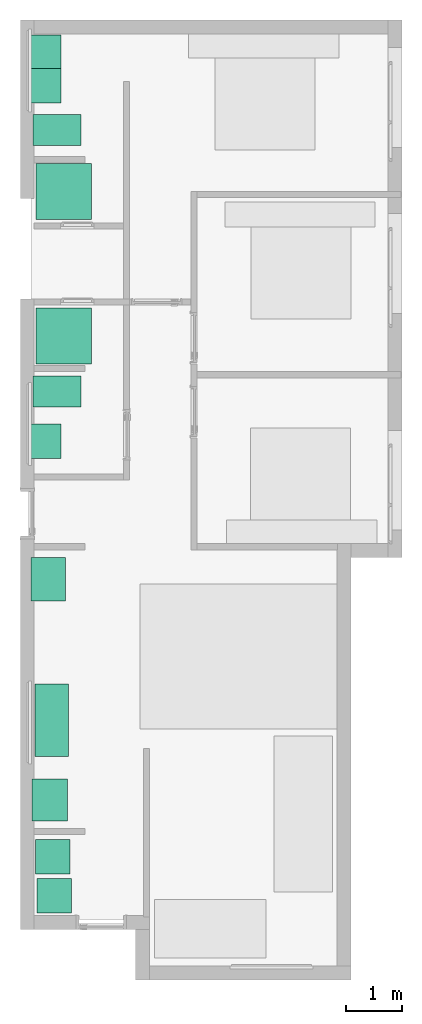
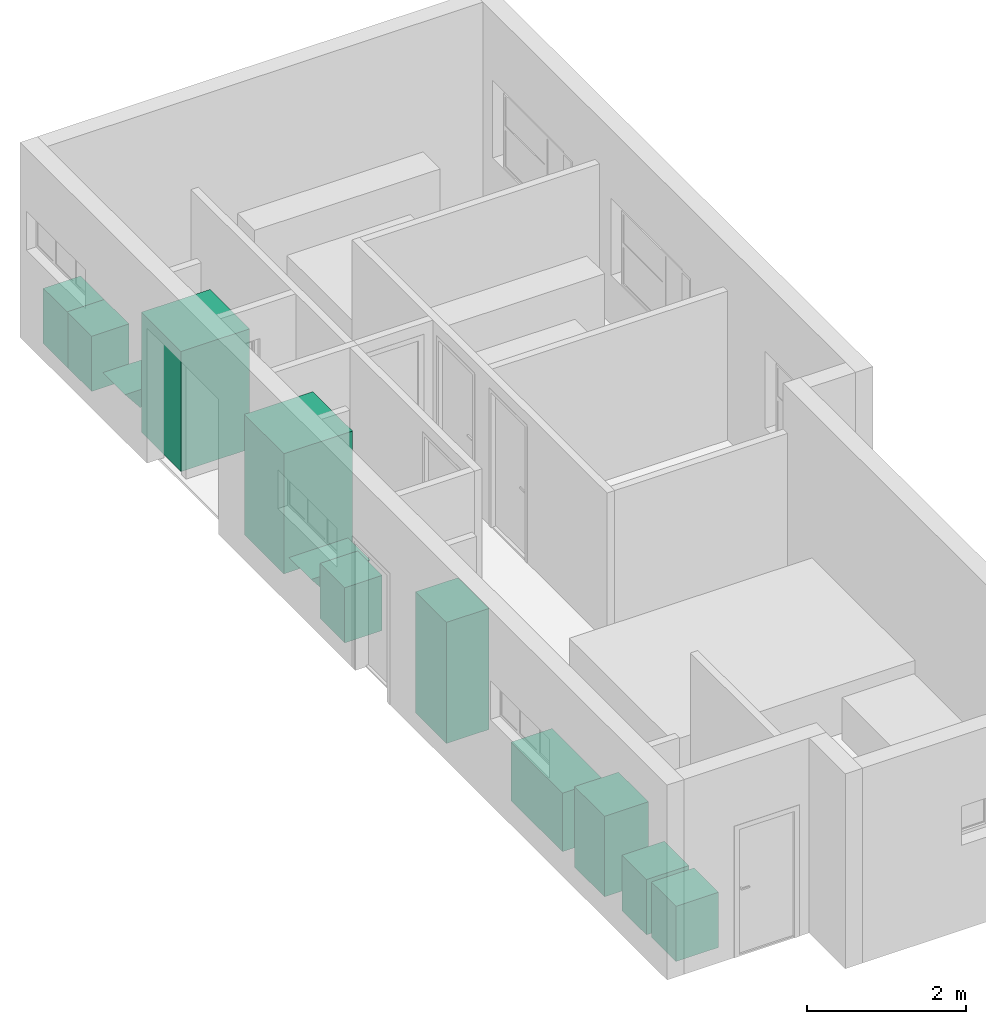
# One storey, part 9 of 10: 8 sanitary terminals, 4 electric appliances.
"""IFC4 building model written with IfcOpenShell, lengths in millimetres."""

from ifc_helpers import new_model, entity, si_unit, converted_unit, frame, origin_with_axes, origin_2d_with_axis, place, context, subcontext, project, spatial, polygons, source, transform, mapped, type_object, type_shapes, element, save


model = new_model("IFC4")

# Units and contexts
model_context = context("Model", 3, precision=1e-05, world=origin_with_axes())
plan_context = context("Plan", 2, precision=1e-05, world=origin_2d_with_axis())
body_context = subcontext(model_context, "Body", "Model", "MODEL_VIEW")
ifc_project = project(units=[si_unit("VOLUMEUNIT", "CUBIC_METRE"), si_unit("LENGTHUNIT", "METRE", prefix="MILLI"), converted_unit("PLANEANGLEUNIT", "degree", entity("IfcReal", 0.0174532925199433), si_unit("PLANEANGLEUNIT", "RADIAN"), dimensions=[0, 0, 0, 0, 0, 0, 0]), si_unit("AREAUNIT", "SQUARE_METRE")], contexts=[model_context, plan_context])

# Site, building, storey
site_placement = place(None, origin_with_axes())
site = spatial("IfcSite", under=ifc_project, at=site_placement)
building_placement = place(site_placement, origin_with_axes())
building = spatial("IfcBuilding", under=site, at=building_placement, Name="Building")
storey_placement = place(building_placement, origin_with_axes())
storey = spatial("IfcBuildingStorey", under=building, at=storey_placement, Name="0-Ground Floor")

# Electric appliances
electric_appliance_type_1 = type_object("IfcElectricApplianceType", Name="13 plate DW", PredefinedType="DISHWASHER")
shared_shape_1 = source(origin_with_axes(), body_context, "Body", "Tessellation", [
    polygons([(-25.4548778533936, -5.45489740371704, 2.98023205687059e-05), (-25.4548778533936, 614.544921875, 2.98023205687059e-05), (-25.4548778533936, -5.45489740371704, 850.0), (-25.4548778533936, 614.544921875, 850.0), (594.545043945312, 614.544921875, 2.98023205687059e-05), (594.545043945312, 614.544921875, 850.0), (594.545043945312, -5.45489740371704, 2.98023205687059e-05), (594.545043945312, -5.45489740371704, 850.0)], [[[2, 4, 6, 5]], [[5, 6, 8, 7]], [[7, 1, 2, 5]], [[3, 8, 6, 4]], [[3, 1, 7, 8]], [[4, 2, 1, 3]]], closed=True),
])
type_shapes(electric_appliance_type_1, [shared_shape_1])
electric_appliance_1_placement = place(storey_placement, frame((1639.33420181274, 2875.96201896667, 0.0), z_axis=(0.0, 0.0, 1.0), x_axis=(1.0, 0.0, 0.0)))
element("IfcElectricAppliance", 1, at=electric_appliance_1_placement, inside=storey, type_object=electric_appliance_type_1, Name="ElectricAppliance", context=body_context, shape_type="MappedRepresentation", body=[
    mapped(shared_shape_1, transform((0.0, 0.0, 0.0), x_axis=(1.0, 0.0, 0.0), y_axis=(0.0, 1.0, 0.0), z_axis=(0.0, 0.0, 1.0), scale=1.0)),
])
electric_appliance_type_2 = type_object("IfcElectricApplianceType", PredefinedType="WASHINGMACHINE")
shared_shape_2 = source(origin_with_axes(), body_context, "Body", "Tessellation", [
    polygons([(1.86264496733202e-05, 0.0, 2.98023205687059e-05), (1.86264496733202e-05, 619.999938964844, 2.98023205687059e-05), (1.86264496733202e-05, 0.0, 850.0), (1.86264496733202e-05, 619.999938964844, 850.0), (619.999938964844, 619.999938964844, 2.98023205687059e-05), (619.999938964844, 619.999938964844, 850.0), (619.999938964844, 0.0, 2.98023205687059e-05), (619.999938964844, 0.0, 850.0)], [[[2, 4, 6, 5]], [[5, 6, 8, 7]], [[7, 1, 2, 5]], [[3, 8, 6, 4]], [[3, 1, 7, 8]], [[4, 2, 1, 3]]], closed=True),
])
type_shapes(electric_appliance_type_2, [shared_shape_2])
electric_appliance_2_placement = place(storey_placement, frame((1643.49460601807, 2175.20189285278, 0.0), z_axis=(0.0, 0.0, 1.0), x_axis=(1.0, 0.0, 0.0)))
element("IfcElectricAppliance", 2, at=electric_appliance_2_placement, inside=storey, type_object=electric_appliance_type_2, Name="ElectricAppliance", context=body_context, shape_type="MappedRepresentation", body=[
    mapped(shared_shape_2, transform((0.0, 0.0, 0.0), x_axis=(1.0, 0.0, 0.0), y_axis=(0.0, 1.0, 0.0), z_axis=(0.0, 0.0, 1.0), scale=1.0)),
])
electric_appliance_type_3 = type_object("IfcElectricApplianceType", PredefinedType="FRIDGE_FREEZER")
shared_shape_3 = source(origin_with_axes(), body_context, "Body", "Tessellation", [
    polygons([(2.98023187497165e-05, 779.999877929688, 2.98023187497165e-05), (619.999877929688, 779.999877929688, 2.98023187497165e-05), (2.98023187497165e-05, 779.999877929688, 1864.99975585938), (619.999877929688, 779.999877929688, 1864.99975585938), (619.999877929688, 2.98023187497165e-05, 2.98023187497165e-05), (619.999877929688, 2.98023187497165e-05, 1864.99975585938), (2.98023187497165e-05, 2.98023187497165e-05, 2.98023187497165e-05), (2.98023187497165e-05, 2.98023187497165e-05, 1864.99975585938)], [[[2, 1, 3]], [[2, 3, 4]], [[6, 5, 2]], [[6, 2, 4]], [[1, 2, 5]], [[1, 5, 7]], [[4, 3, 8]], [[4, 8, 6]], [[5, 6, 8]], [[5, 8, 7]], [[8, 3, 1]], [[8, 1, 7]]], closed=True),
])
type_shapes(electric_appliance_type_3, [shared_shape_3])
electric_appliance_3_placement = place(storey_placement, frame((2153.04899215698, 8553.37905883789, 0.0), z_axis=(0.0, 0.0, 1.0), x_axis=(-0.999999999999989, 1.50995802528085e-07, 0.0)))
element("IfcElectricAppliance", 3, at=electric_appliance_3_placement, inside=storey, type_object=electric_appliance_type_3, Name="ElectricAppliance", context=body_context, shape_type="MappedRepresentation", body=[
    mapped(shared_shape_3, transform((0.0, 0.0, 0.0), x_axis=(1.0, 0.0, 0.0), y_axis=(0.0, 1.0, 0.0), z_axis=(0.0, 0.0, 1.0), scale=1.0)),
])
electric_appliance_type_4 = type_object("IfcElectricApplianceType", PredefinedType="ELECTRICCOOKER")
shared_shape_4 = source(origin_with_axes(), body_context, "Body", "Tessellation", [
    polygons([(-3.21423983573914, 11.3971147537231, 26.0084190368652), (-3.21423983573914, 11.3971147537231, 1266.00842285156), (-3.21423983573914, 651.397094726562, 26.0084190368652), (-3.21423983573914, 651.397094726562, 1266.00842285156), (751.785705566406, 11.3971147537231, 26.0084190368652), (751.785705566406, 11.3971147537231, 1266.00842285156), (751.785705566406, 651.397094726562, 26.0084190368652), (751.785705566406, 651.397094726562, 1266.00842285156)], [[[1, 2, 4, 3]], [[3, 4, 8, 7]], [[7, 8, 6, 5]], [[5, 6, 2, 1]], [[3, 7, 5, 1]], [[8, 4, 2, 6]]], closed=True),
])
type_shapes(electric_appliance_type_4, [shared_shape_4])
electric_appliance_4_placement = place(storey_placement, frame((1543.6372756958, 4577.67343521118, 0.0), z_axis=(0.0, 0.0, 1.0), x_axis=(7.54979012640431e-08, -0.999999999999997, 0.0)))
element("IfcElectricAppliance", 4, at=electric_appliance_4_placement, inside=storey, type_object=electric_appliance_type_4, Name="ElectricAppliance", context=body_context, shape_type="MappedRepresentation", body=[
    mapped(shared_shape_4, transform((0.0, 0.0, 0.0), x_axis=(1.0, 0.0, 0.0), y_axis=(0.0, 1.0, 0.0), z_axis=(0.0, 0.0, 1.0), scale=1.0)),
])

# Sanitary terminals
sanitary_terminal_type_1 = type_object("IfcSanitaryTerminalType", Name="Shower", PredefinedType="SHOWER")
shared_shape_5 = source(origin_with_axes(), body_context, "Body", "Tessellation", [
    polygons([(0.0, 2.98023205687059e-05, 2.98023205687059e-05), (0.0, 999.999938964844, 2.98023205687059e-05), (0.0, 2.98023205687059e-05, 1849.99987792969), (0.0, 999.999938964844, 1849.99987792969), (999.999938964844, 999.999938964844, 2.98023205687059e-05), (999.999938964844, 999.999938964844, 1849.99987792969), (999.999938964844, 2.98023205687059e-05, 2.98023205687059e-05), (999.999938964844, 2.98023205687059e-05, 1849.99987792969)], [[[2, 4, 6, 5]], [[5, 6, 8, 7]], [[7, 1, 2, 5]], [[3, 8, 6, 4]], [[3, 1, 7, 8]], [[4, 2, 1, 3]]], closed=True),
])
type_shapes(sanitary_terminal_type_1, [shared_shape_5])
for number, where, z_axis, x_axis, name in (
    (5, (1622.69151210785, 12028.7218093872, 0.0), (0.0, 0.0, 1.0), (1.0, 0.0, 0.0), "SanitaryTerminal"),
    (6, (1622.69151210785, 14624.2475509644, 0.0), (0.0, 0.0, 1.0), (1.0, 0.0, 0.0), "SanitaryTerminal"),
):
    element("IfcSanitaryTerminal", number, at=place(storey_placement, frame(where, z_axis=z_axis, x_axis=x_axis)), inside=storey, type_object=sanitary_terminal_type_1, Name=name, context=body_context, shape_type="MappedRepresentation", body=[
        mapped(shared_shape_5, transform((0.0, 0.0, 0.0), x_axis=(1.0, 0.0, 0.0), y_axis=(0.0, 1.0, 0.0), z_axis=(0.0, 0.0, 1.0), scale=1.0)),
    ])
sanitary_terminal_type_2 = type_object("IfcSanitaryTerminalType", Name="Single basin", PredefinedType="WASHHANDBASIN")
shared_shape_6 = source(origin_with_axes(), body_context, "Body", "Tessellation", [
    polygons([(-499.999969482422, -499.999938964844, 2.98023205687059e-05), (-499.999969482422, 44.9999542236328, 2.98023205687059e-05), (-499.999969482422, -499.999938964844, 850.0), (-499.999969482422, 44.9999542236328, 850.0), (119.999938964844, 44.9999542236328, 2.98023205687059e-05), (119.999938964844, 44.9999542236328, 850.0), (119.999938964844, -499.999938964844, 2.98023205687059e-05), (119.999938964844, -499.999938964844, 850.0)], [[[2, 4, 6, 5]], [[5, 6, 8, 7]], [[7, 1, 2, 5]], [[3, 8, 6, 4]], [[3, 1, 7, 8]], [[4, 2, 1, 3]]], closed=True),
])
type_shapes(sanitary_terminal_type_2, [shared_shape_6])
for number, where, z_axis, x_axis, name in (
    (7, (1572.76248931885, 10830.4252624512, 0.0), (0.0, 0.0, 1.0), (7.54979012640431e-08, 0.999999999999997, 0.0), "SanitaryTerminal"),
    (8, (1572.76248931885, 17815.1626586914, 0.0), (0.0, 0.0, 1.0), (7.54979012640431e-08, 0.999999999999997, 0.0), "SanitaryTerminal"),
    (9, (1572.76248931885, 17215.1622772217, 0.0), (0.0, 0.0, 1.0), (7.54979012640431e-08, 0.999999999999997, 0.0), "SanitaryTerminal"),
):
    element("IfcSanitaryTerminal", number, at=place(storey_placement, frame(where, z_axis=z_axis, x_axis=x_axis)), inside=storey, type_object=sanitary_terminal_type_2, Name=name, context=body_context, shape_type="MappedRepresentation", body=[
        mapped(shared_shape_6, transform((0.0, 0.0, 0.0), x_axis=(1.0, 0.0, 0.0), y_axis=(0.0, 1.0, 0.0), z_axis=(0.0, 0.0, 1.0), scale=1.0)),
    ])
sanitary_terminal_type_3 = type_object("IfcSanitaryTerminalType", Name="Sink", PredefinedType="SINK")
shared_shape_7 = source(origin_with_axes(), body_context, "Body", "Tessellation", [
    polygons([(0.0, 0.0, 2.98023205687059e-05), (0.0, 1299.99987792969, 2.98023205687059e-05), (0.0, 0.0, 899.999938964844), (0.0, 1299.99987792969, 899.999938964844), (600.0, 1299.99987792969, 2.98023205687059e-05), (600.0, 1299.99987792969, 899.999938964844), (600.0, 0.0, 2.98023205687059e-05), (600.0, 0.0, 899.999938964844)], [[[2, 4, 6, 5]], [[5, 6, 8, 7]], [[7, 1, 2, 5]], [[3, 8, 6, 4]], [[3, 1, 7, 8]], [[4, 2, 1, 3]]], closed=True),
])
type_shapes(sanitary_terminal_type_3, [shared_shape_7])
sanitary_terminal_placement = place(storey_placement, frame((1610.2089881897, 4983.10518264771, 0.0), z_axis=(0.0, 0.0, 1.0), x_axis=(1.0, 0.0, 0.0)))
element("IfcSanitaryTerminal", 10, at=sanitary_terminal_placement, inside=storey, type_object=sanitary_terminal_type_3, Name="SanitaryTerminal", context=body_context, shape_type="MappedRepresentation", body=[
    mapped(shared_shape_7, transform((0.0, 0.0, 0.0), x_axis=(1.0, 0.0, 0.0), y_axis=(0.0, 1.0, 0.0), z_axis=(0.0, 0.0, 1.0), scale=1.0)),
])
sanitary_terminal_type_4 = type_object("IfcSanitaryTerminalType", Name="Toilet", PredefinedType="TOILETPAN")
shared_shape_8 = source(origin_with_axes(), body_context, "Body", "Tessellation", [
    polygons([(308.008087158203, 354.004028320312, 1.49011593748583e-05), (508.008026123047, 354.004028320312, -1.49011593748583e-05), (2.98023187497165e-05, 559.999938964844, 399.999938964844), (859.999938964844, 559.999938964844, 399.999938964844), (508.008026123047, 154.004028320312, -1.49011593748583e-05), (859.999938964844, 5.9604637499433e-05, 399.999938964844), (308.008087158203, 154.004028320312, 1.49011593748583e-05), (2.98023187497165e-05, 5.9604637499433e-05, 399.999938964844)], [[[6, 5, 2, 4]], [[8, 6, 4, 3]], [[5, 6, 8, 7]], [[5, 7, 1, 2]], [[3, 1, 7, 8]], [[1, 3, 4, 2]]], closed=True),
])
type_shapes(sanitary_terminal_type_4, [shared_shape_8])
for number, where, z_axis, x_axis, name in (
    (11, (1572.76248931885, 11254.8217773438, 0.0), (0.0, 0.0, 1.0), (1.0, 0.0, 0.0), "SanitaryTerminal"),
    (12, (1572.76248931885, 15949.0356445312, 0.0), (0.0, 0.0, 1.0), (1.0, 0.0, 0.0), "SanitaryTerminal"),
):
    element("IfcSanitaryTerminal", number, at=place(storey_placement, frame(where, z_axis=z_axis, x_axis=x_axis)), inside=storey, type_object=sanitary_terminal_type_4, Name=name, context=body_context, shape_type="MappedRepresentation", body=[
        mapped(shared_shape_8, transform((0.0, 0.0, 0.0), x_axis=(1.0, 0.0, 0.0), y_axis=(0.0, 1.0, 0.0), z_axis=(0.0, 0.0, 1.0), scale=1.0)),
    ])

save(model, "model.ifc")
